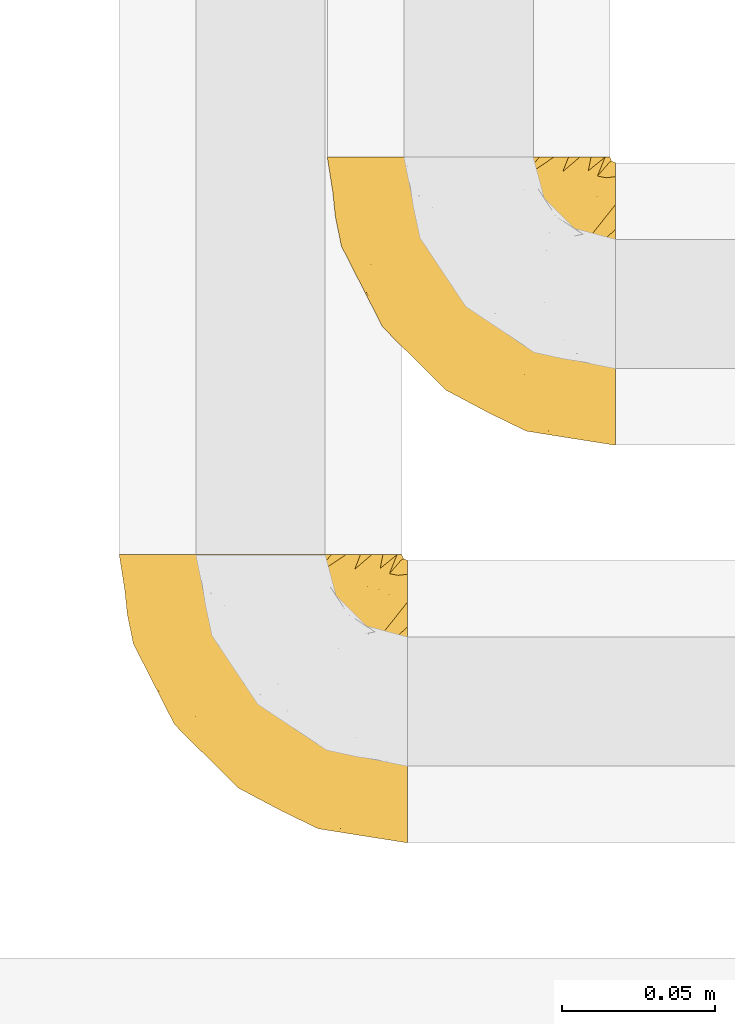
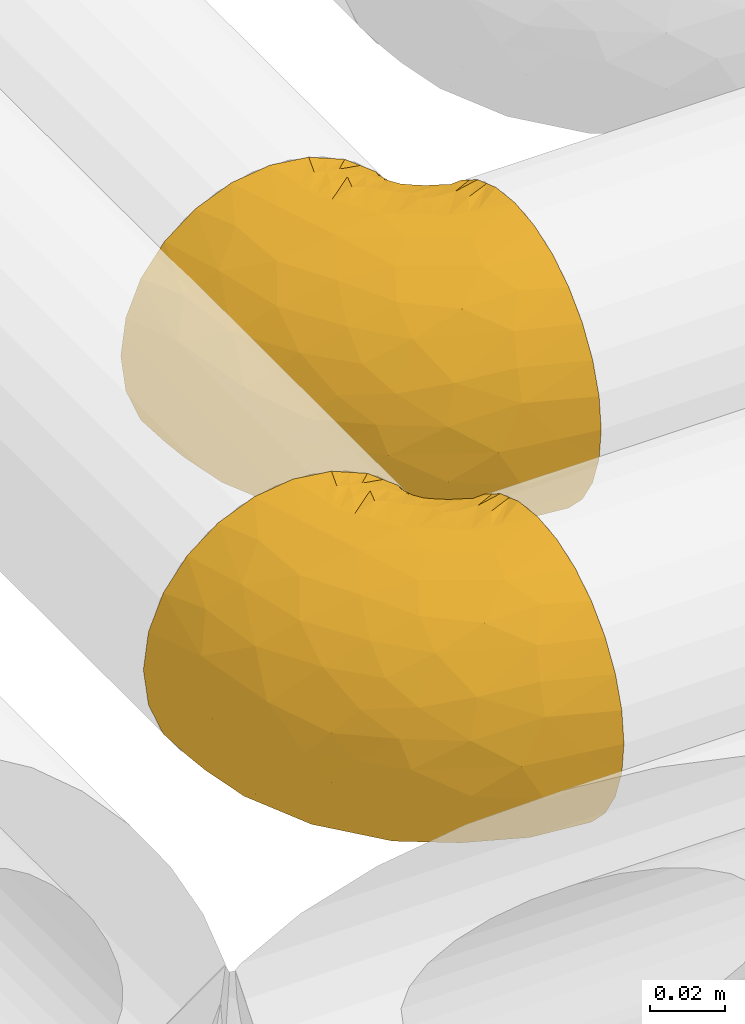
# One storey, part 259 of 827: 2 coverings.
"""IFC2X3 building model written with IfcOpenShell, lengths in millimetres."""

from ifc_helpers import new_model, entity, si_unit, converted_unit, derived_unit, direction, frame, origin, place, context, subcontext, project, spatial, faceted_brep, element, save


model = new_model("IFC2X3")

# Units and contexts
model_context = context("Model", 3, precision=0.01, world=origin(), true_north=direction((6.12303176911189e-17, 1.0)))
body_context = subcontext(model_context, "Body", "Model", "MODEL_VIEW")
ifc_project = project(units=[si_unit("LENGTHUNIT", "METRE", prefix="MILLI"), si_unit("AREAUNIT", "SQUARE_METRE"), si_unit("VOLUMEUNIT", "CUBIC_METRE"), converted_unit("PLANEANGLEUNIT", "DEGREE", entity("IfcRatioMeasure", 0.0174532925199433), si_unit("PLANEANGLEUNIT", "RADIAN"), dimensions=[0, 0, 0, 0, 0, 0, 0]), si_unit("MASSUNIT", "GRAM", prefix="KILO"), derived_unit("MASSDENSITYUNIT", [(si_unit("MASSUNIT", "GRAM", prefix="KILO"), 1), (si_unit("LENGTHUNIT", "METRE"), -3)]), derived_unit("MOMENTOFINERTIAUNIT", [(si_unit("LENGTHUNIT", "METRE"), 4)]), si_unit("TIMEUNIT", "SECOND"), si_unit("FREQUENCYUNIT", "HERTZ"), si_unit("THERMODYNAMICTEMPERATUREUNIT", "DEGREE_CELSIUS"), derived_unit("THERMALTRANSMITTANCEUNIT", [(si_unit("MASSUNIT", "GRAM", prefix="KILO"), 1), (si_unit("THERMODYNAMICTEMPERATUREUNIT", "KELVIN"), -1), (si_unit("TIMEUNIT", "SECOND"), -3)]), derived_unit("VOLUMETRICFLOWRATEUNIT", [(si_unit("LENGTHUNIT", "METRE"), 3), (si_unit("TIMEUNIT", "SECOND"), -1)]), derived_unit("MASSFLOWRATEUNIT", [(si_unit("MASSUNIT", "GRAM", prefix="KILO"), 1), (si_unit("TIMEUNIT", "SECOND"), -1)]), derived_unit("ROTATIONALFREQUENCYUNIT", [(si_unit("TIMEUNIT", "SECOND"), -1)]), si_unit("ELECTRICCURRENTUNIT", "AMPERE"), si_unit("ELECTRICVOLTAGEUNIT", "VOLT"), si_unit("POWERUNIT", "WATT"), si_unit("FORCEUNIT", "NEWTON", prefix="KILO"), si_unit("ILLUMINANCEUNIT", "LUX"), si_unit("LUMINOUSFLUXUNIT", "LUMEN"), si_unit("LUMINOUSINTENSITYUNIT", "CANDELA"), derived_unit("USERDEFINED", [(si_unit("MASSUNIT", "GRAM", prefix="KILO"), -1), (si_unit("LENGTHUNIT", "METRE"), -2), (si_unit("TIMEUNIT", "SECOND"), 3), (si_unit("LUMINOUSFLUXUNIT", "LUMEN"), 1)]), derived_unit("LINEARVELOCITYUNIT", [(si_unit("LENGTHUNIT", "METRE"), 1), (si_unit("TIMEUNIT", "SECOND"), -1)]), si_unit("PRESSUREUNIT", "PASCAL"), derived_unit("USERDEFINED", [(si_unit("LENGTHUNIT", "METRE"), -2), (si_unit("MASSUNIT", "GRAM", prefix="KILO"), 1), (si_unit("TIMEUNIT", "SECOND"), -2)]), derived_unit("LINEARFORCEUNIT", [(si_unit("MASSUNIT", "GRAM", prefix="KILO"), 1), (si_unit("LENGTHUNIT", "METRE"), 1), (si_unit("TIMEUNIT", "SECOND"), -2), (si_unit("LENGTHUNIT", "METRE"), -1)]), derived_unit("PLANARFORCEUNIT", [(si_unit("MASSUNIT", "GRAM", prefix="KILO"), 1), (si_unit("LENGTHUNIT", "METRE"), 1), (si_unit("TIMEUNIT", "SECOND"), -2), (si_unit("LENGTHUNIT", "METRE"), -2)])], contexts=[model_context])

# Site, building, storey
site_placement = place(None, origin())
site = spatial("IfcSite", under=ifc_project, at=site_placement, CompositionType="ELEMENT")
building_placement = place(site_placement, origin())
building = spatial("IfcBuilding", under=site, at=building_placement, CompositionType="ELEMENT")
storey_placement = place(building_placement, frame((0.0, 0.0, 28200.0)))
storey = spatial("IfcBuildingStorey", under=building, at=storey_placement, Name="08", CompositionType="ELEMENT", Elevation=28200.0)

# Coverings
covering_1_placement = place(storey_placement, frame((30677.28, 17203.41, 2952.2)))
element("IfcCovering", 1, at=covering_1_placement, inside=storey, Name=":ADSK_", ObjectType=":ADSK_", PredefinedType="INSULATION", context=body_context, shape_type="Brep", body=[
    faceted_brep([(95.8, 37.51, 92.84), (95.8, 27.74, 89.42), (95.8, 18.98, 83.91), (95.8, 11.67, 76.59), (95.8, 6.17, 67.83), (95.8, 2.75, 58.07), (95.8, 1.6, 47.8), (95.8, 2.75, 37.51), (95.8, 6.17, 27.74), (95.8, 11.68, 18.98), (95.8, 19.0, 11.67), (95.8, 27.76, 6.17), (95.8, 37.52, 2.75), (95.8, 47.8, 1.6), (95.8, 51.94, 2.06), (95.8, 55.01, 2.41), (95.8, 58.08, 2.75), (95.8, 62.96, 4.46), (95.8, 67.85, 6.17), (95.8, 72.23, 8.93), (95.8, 76.61, 11.68), (95.8, 80.26, 15.34), (95.8, 83.92, 19.0), (95.8, 89.42, 27.76), (95.8, 91.13, 32.64), (95.8, 92.84, 37.52), (95.8, 94.0, 47.8), (95.8, 92.84, 58.08), (95.8, 91.13, 62.96), (95.8, 89.42, 67.85), (95.8, 83.91, 76.61), (95.8, 80.25, 80.26), (95.8, 76.59, 83.92), (95.8, 72.21, 86.67), (95.8, 67.83, 89.42), (95.8, 62.95, 91.13), (95.8, 58.07, 92.84), (95.8, 55.0, 93.18), (95.8, 51.94, 93.53), (95.8, 47.8, 94.0), (94.0, 95.8, 47.8), (92.42, 95.8, 35.84), (87.81, 95.8, 24.7), (84.13, 95.8, 19.91), (80.46, 95.8, 15.13), (75.68, 95.8, 11.46), (70.9, 95.8, 7.78), (65.32, 95.8, 5.48), (59.75, 95.8, 3.17), (56.14, 95.8, 2.69), (54.06, 95.8, 2.42), (51.97, 95.8, 2.14), (47.8, 95.8, 1.6), (35.84, 95.8, 3.17), (24.7, 95.8, 7.78), (15.13, 95.8, 15.13), (7.78, 95.8, 24.7), (3.17, 95.8, 35.84), (1.6, 95.8, 47.8), (3.17, 95.8, 59.75), (7.78, 95.8, 70.9), (15.13, 95.8, 80.46), (24.7, 95.8, 87.81), (35.84, 95.8, 92.42), (47.8, 95.8, 94.0), (51.97, 95.8, 93.45), (56.14, 95.8, 92.9), (59.75, 95.8, 92.42), (65.32, 95.8, 90.11), (70.9, 95.8, 87.81), (75.68, 95.8, 84.13), (80.46, 95.8, 80.46), (84.13, 95.8, 75.68), (87.81, 95.8, 70.9), (92.42, 95.8, 59.75), (15.84, 60.58, 71.98), (6.99, 74.11, 63.6), (14.39, 51.59, 59.72), (6.21, 66.69, 47.8), (4.26, 76.19, 55.16), (3.39, 84.43, 47.8), (31.2, 31.2, 63.76), (26.47, 42.88, 72.22), (11.44, 79.41, 74.18), (47.66, 60.7, 92.52), (61.85, 61.85, 94.0), (59.25, 65.75, 94.0), (56.65, 69.64, 94.0), (54.05, 73.53, 94.0), (51.45, 77.43, 94.0), (19.8, 74.59, 82.14), (26.22, 54.72, 80.34), (31.58, 64.18, 87.52), (38.36, 37.94, 79.59), (51.54, 25.89, 78.25), (51.6, 34.73, 85.01), (55.97, 42.89, 90.25), (62.88, 49.83, 93.2), (41.35, 48.58, 87.23), (82.24, 22.41, 85.55), (40.88, 78.69, 93.0), (29.0, 81.64, 89.31), (74.06, 6.22, 61.31), (54.53, 12.11, 56.86), (57.98, 14.81, 68.34), (43.81, 21.61, 65.71), (38.22, 22.41, 56.99), (38.33, 30.12, 72.15), (74.76, 10.01, 70.34), (76.85, 15.36, 78.36), (84.43, 3.39, 47.8), (40.43, 19.59, 47.8), (30.01, 30.01, 47.8), (78.67, 41.19, 93.06), (92.06, 48.54, 94.0), (88.32, 49.28, 94.0), (85.6, 49.82, 94.0), (82.88, 50.37, 94.0), (80.15, 50.91, 94.0), (77.43, 51.45, 94.0), (76.36, 31.61, 89.88), (50.91, 80.15, 94.0), (50.37, 82.88, 94.0), (49.82, 85.6, 94.0), (49.28, 88.32, 94.0), (48.91, 90.19, 94.0), (48.54, 92.06, 94.0), (66.69, 6.21, 47.8), (73.53, 54.05, 94.0), (69.64, 56.65, 94.0), (65.75, 59.25, 94.0), (66.13, 24.66, 83.7), (19.59, 40.43, 47.8), (24.64, 35.17, 55.9), (53.56, 12.9, 47.8), (12.9, 53.56, 47.8), (82.81, 85.34, 81.75), (81.22, 78.44, 86.43), (86.57, 84.37, 79.8), (92.75, 89.05, 69.84), (89.68, 82.76, 79.5), (72.26, 86.31, 88.08), (64.73, 83.73, 91.6), (62.45, 77.31, 92.93), (60.63, 87.78, 92.43), (56.91, 87.91, 93.24), (58.14, 81.29, 93.36), (93.7, 93.97, 57.25), (83.4, 70.76, 89.41), (75.54, 63.67, 92.89), (79.46, 62.62, 92.66), (82.28, 90.64, 79.58), (76.25, 84.08, 86.51), (90.18, 77.45, 83.91), (84.69, 76.28, 86.29), (65.12, 88.72, 90.94), (71.71, 71.28, 91.94), (75.21, 68.09, 91.98), (78.6, 91.07, 82.79), (87.27, 57.47, 93.16), (87.92, 70.34, 88.76), (86.94, 91.35, 73.94), (86.1, 62.99, 91.89), (94.52, 94.52, 47.8), (66.23, 76.47, 92.22), (91.08, 69.96, 88.56), (71.77, 89.86, 87.72), (76.21, 78.94, 88.33), (68.59, 73.51, 92.18), (89.94, 89.62, 71.78), (76.22, 78.96, 7.27), (81.22, 78.46, 9.17), (71.7, 71.31, 3.66), (48.54, 92.06, 1.6), (50.37, 82.88, 1.6), (49.82, 85.6, 1.6), (49.28, 88.32, 1.6), (93.7, 93.97, 38.35), (89.95, 89.63, 23.84), (82.88, 50.37, 1.6), (85.6, 49.82, 1.6), (92.06, 48.54, 1.6), (88.32, 49.28, 1.6), (89.68, 82.77, 16.1), (87.92, 70.36, 6.84), (62.45, 77.31, 2.66), (66.24, 76.47, 3.37), (56.65, 69.64, 1.6), (59.25, 65.75, 1.6), (78.6, 91.06, 12.8), (60.63, 87.78, 3.16), (56.91, 87.91, 2.35), (92.76, 89.06, 25.77), (76.25, 84.09, 9.09), (82.28, 90.65, 16.02), (82.81, 85.35, 13.85), (54.05, 73.53, 1.6), (51.45, 77.43, 1.6), (58.14, 81.29, 2.23), (90.18, 77.46, 11.69), (84.7, 76.29, 9.31), (87.25, 57.47, 2.43), (75.58, 63.71, 2.71), (75.2, 68.11, 3.61), (83.39, 70.77, 6.18), (90.73, 69.52, 6.77), (79.47, 62.64, 2.93), (86.94, 91.35, 21.66), (65.75, 59.25, 1.6), (86.75, 84.6, 16.09), (86.08, 62.98, 3.7), (77.43, 51.45, 1.6), (73.53, 54.05, 1.6), (69.64, 56.65, 1.6), (64.73, 83.73, 3.99), (50.91, 80.15, 1.6), (65.12, 88.72, 4.65), (72.26, 86.3, 7.51), (61.85, 61.85, 1.6), (68.62, 73.56, 3.43), (74.03, 91.36, 9.46), (80.15, 50.91, 1.6), (49.81, 62.87, 2.4), (4.26, 76.19, 40.43), (19.95, 73.57, 13.57), (30.61, 56.07, 11.3), (25.71, 49.77, 18.65), (22.43, 44.73, 27.26), (15.85, 60.58, 23.61), (60.69, 47.64, 3.07), (40.49, 78.32, 2.69), (14.39, 51.59, 35.87), (6.99, 74.11, 31.99), (29.56, 76.04, 6.71), (11.45, 79.41, 21.41), (57.98, 14.82, 27.24), (74.06, 6.22, 34.26), (54.52, 12.12, 38.73), (43.47, 23.51, 26.97), (31.2, 31.2, 31.83), (33.27, 34.96, 23.4), (64.26, 33.86, 6.91), (74.29, 38.94, 3.4), (80.41, 30.23, 5.84), (24.64, 35.17, 39.69), (73.62, 15.85, 17.6), (78.98, 22.59, 10.38), (53.69, 21.56, 20.6), (42.86, 55.94, 5.36), (41.67, 20.67, 35.73), (79.66, 9.19, 24.84), (58.41, 25.79, 13.87), (47.11, 41.16, 9.06), (38.37, 37.95, 15.99)], [[[0, 1, 2, 3, 4, 5, 6, 7, 8, 9, 10, 11, 12, 13, 14, 15, 16, 17, 18, 19, 20, 21, 22, 23, 24, 25, 26, 27, 28, 29, 30, 31, 32, 33, 34, 35, 36, 37, 38, 39]], [[40, 41, 42, 43, 44, 45, 46, 47, 48, 49, 50, 51, 52, 53, 54, 55, 56, 57, 58, 59, 60, 61, 62, 63, 64, 65, 66, 67, 68, 69, 70, 71, 72, 73, 74]], [[75, 76, 77]], [[78, 79, 80]], [[77, 81, 82]], [[76, 75, 83]], [[84, 85, 86, 87, 88, 89]], [[90, 91, 92]], [[76, 60, 59]], [[93, 94, 95]], [[90, 62, 61]], [[83, 61, 60]], [[96, 97, 84]], [[98, 93, 95]], [[2, 1, 99]], [[100, 84, 89]], [[62, 101, 63]], [[4, 102, 5]], [[92, 84, 100]], [[103, 102, 104]], [[103, 105, 106]], [[93, 107, 94]], [[3, 108, 4]], [[92, 101, 90]], [[108, 3, 109]], [[102, 110, 5]], [[93, 82, 107]], [[102, 108, 104]], [[111, 106, 112]], [[109, 2, 99]], [[113, 39, 114, 115, 116, 117, 118, 119]], [[120, 0, 113]], [[100, 89, 121, 122, 123, 124, 125, 126, 64]], [[127, 102, 103]], [[97, 119, 128, 129, 130, 85]], [[99, 120, 131]], [[132, 133, 77]], [[59, 80, 79]], [[3, 2, 109]], [[98, 84, 92]], [[94, 109, 131]], [[120, 1, 0]], [[93, 91, 82]], [[104, 94, 105]], [[97, 113, 119]], [[95, 120, 96]], [[83, 90, 61]], [[91, 93, 98]], [[64, 63, 100]], [[100, 63, 101]], [[77, 76, 79]], [[133, 106, 81]], [[84, 97, 85]], [[113, 96, 120]], [[113, 97, 96]], [[39, 113, 0]], [[110, 102, 127]], [[110, 6, 5]], [[103, 111, 134, 127]], [[90, 75, 91]], [[82, 81, 107]], [[91, 75, 82]], [[77, 82, 75]], [[76, 83, 60]], [[90, 83, 75]], [[105, 107, 81]], [[94, 131, 95]], [[105, 94, 107]], [[109, 94, 104]], [[120, 95, 131]], [[98, 95, 96]], [[84, 98, 96]], [[98, 92, 91]], [[106, 105, 81]], [[103, 104, 105]], [[133, 132, 112]], [[103, 106, 111]], [[77, 78, 135, 132]], [[106, 133, 112]], [[77, 133, 81]], [[120, 99, 1]], [[109, 99, 131]], [[59, 58, 80]], [[59, 79, 76]], [[90, 101, 62]], [[100, 101, 92]], [[4, 108, 102]], [[109, 104, 108]], [[78, 77, 79]], [[136, 137, 138]], [[29, 139, 140]], [[141, 142, 143]], [[144, 145, 121]], [[146, 89, 88]], [[147, 139, 27]], [[148, 149, 150]], [[136, 151, 152]], [[147, 40, 74]], [[26, 147, 27]], [[153, 140, 154]], [[35, 116, 36]], [[73, 72, 151]], [[114, 39, 38, 37, 36, 116, 115]], [[146, 155, 144]], [[156, 85, 130]], [[157, 149, 148]], [[151, 158, 152]], [[117, 35, 159]], [[31, 153, 160]], [[161, 74, 73]], [[162, 128, 119]], [[65, 64, 126, 125, 124, 123, 122, 67, 66]], [[163, 147, 26]], [[29, 140, 30]], [[149, 129, 150]], [[139, 29, 28, 27]], [[68, 144, 69]], [[129, 128, 150]], [[164, 87, 86]], [[130, 129, 149]], [[122, 145, 67]], [[153, 154, 148]], [[162, 119, 159]], [[165, 32, 160]], [[150, 160, 148]], [[128, 162, 150]], [[32, 165, 33]], [[145, 144, 68]], [[89, 146, 144]], [[87, 164, 143]], [[166, 155, 142]], [[88, 87, 143]], [[162, 160, 150]], [[160, 32, 31]], [[160, 153, 148]], [[30, 140, 153]], [[31, 30, 153]], [[140, 137, 154]], [[157, 148, 154]], [[156, 130, 157]], [[154, 137, 157]], [[157, 137, 156]], [[167, 137, 136]], [[168, 85, 156]], [[152, 168, 167]], [[167, 168, 156]], [[164, 152, 141]], [[71, 158, 72]], [[152, 167, 136]], [[88, 142, 146]], [[144, 155, 69]], [[146, 142, 155]], [[70, 166, 71]], [[142, 141, 166]], [[70, 69, 155]], [[141, 158, 71]], [[161, 73, 151]], [[138, 137, 140]], [[161, 136, 169]], [[136, 161, 151]], [[74, 161, 169]], [[152, 158, 141]], [[151, 72, 158]], [[168, 152, 164]], [[137, 167, 156]], [[164, 86, 168]], [[85, 168, 86]], [[116, 35, 117]], [[130, 149, 157]], [[67, 145, 68]], [[121, 89, 144]], [[145, 122, 121]], [[40, 147, 163]], [[169, 147, 74]], [[159, 35, 34]], [[162, 159, 34]], [[159, 119, 118, 117]], [[139, 147, 169]], [[139, 169, 138]], [[162, 34, 33]], [[141, 143, 164]], [[88, 143, 142]], [[71, 166, 141]], [[155, 166, 70]], [[139, 138, 140]], [[169, 136, 138]], [[160, 162, 165]], [[162, 33, 165]], [[170, 171, 172]], [[173, 52, 51, 50, 49, 48, 174, 175, 176]], [[177, 178, 41]], [[179, 17, 180]], [[14, 13, 181, 182, 180, 16, 15]], [[183, 23, 22]], [[21, 20, 184]], [[185, 186, 187]], [[186, 188, 187]], [[43, 189, 44]], [[190, 191, 47]], [[25, 24, 23, 192]], [[193, 194, 195]], [[40, 163, 177]], [[196, 197, 198]], [[26, 25, 177]], [[199, 200, 183]], [[201, 17, 179]], [[47, 46, 190]], [[202, 203, 204]], [[203, 172, 171]], [[205, 206, 184]], [[207, 41, 178]], [[18, 17, 201]], [[16, 180, 17]], [[204, 203, 200]], [[208, 203, 202]], [[163, 26, 177]], [[48, 47, 191]], [[198, 197, 190]], [[199, 184, 204]], [[171, 195, 209]], [[210, 211, 212]], [[206, 212, 213]], [[205, 19, 210]], [[184, 206, 204]], [[210, 212, 206]], [[185, 196, 214]], [[190, 215, 191]], [[216, 45, 214]], [[186, 217, 193]], [[190, 216, 198]], [[21, 184, 199]], [[196, 185, 187]], [[21, 199, 22]], [[200, 199, 204]], [[183, 22, 199]], [[206, 202, 204]], [[171, 183, 200]], [[203, 208, 172]], [[172, 208, 218]], [[171, 200, 203]], [[218, 188, 219]], [[195, 170, 193]], [[217, 186, 185]], [[193, 219, 186]], [[193, 170, 219]], [[207, 194, 42]], [[217, 220, 189]], [[216, 190, 46]], [[214, 196, 198]], [[44, 220, 45]], [[214, 198, 216]], [[216, 46, 45]], [[214, 45, 220]], [[42, 194, 43]], [[189, 193, 217]], [[207, 195, 194]], [[209, 195, 178]], [[41, 207, 42]], [[195, 207, 178]], [[43, 194, 189]], [[193, 189, 194]], [[171, 170, 195]], [[170, 172, 219]], [[218, 219, 172]], [[188, 186, 219]], [[206, 213, 202]], [[208, 202, 213]], [[201, 210, 18]], [[215, 190, 197]], [[215, 174, 191]], [[174, 48, 191]], [[201, 179, 221, 211]], [[210, 201, 211]], [[25, 192, 177]], [[40, 177, 41]], [[183, 209, 192]], [[183, 192, 23]], [[192, 178, 177]], [[205, 20, 19]], [[19, 18, 210]], [[217, 185, 214]], [[189, 220, 44]], [[214, 220, 217]], [[192, 209, 178]], [[171, 209, 183]], [[206, 205, 210]], [[20, 205, 184]], [[222, 197, 196, 187, 188, 218]], [[57, 223, 80]], [[224, 225, 226]], [[226, 227, 228]], [[229, 218, 208, 213, 212, 211]], [[230, 52, 173, 176, 175, 174, 215, 197]], [[231, 232, 228]], [[231, 78, 223]], [[223, 57, 232]], [[224, 233, 225]], [[233, 54, 53]], [[234, 232, 56]], [[56, 55, 234]], [[234, 224, 228]], [[235, 236, 237]], [[224, 55, 54]], [[238, 239, 240]], [[52, 230, 53]], [[241, 242, 243]], [[227, 244, 231]], [[13, 12, 242]], [[236, 8, 7]], [[9, 245, 10]], [[10, 246, 11]], [[238, 247, 235]], [[222, 229, 248]], [[242, 211, 221, 179, 180, 182, 181, 13]], [[233, 53, 230]], [[111, 112, 249]], [[250, 8, 236]], [[246, 251, 241]], [[8, 250, 9]], [[127, 236, 110]], [[248, 229, 252]], [[246, 10, 245]], [[235, 245, 250]], [[236, 7, 110]], [[235, 249, 238]], [[237, 236, 127]], [[243, 11, 246]], [[252, 229, 241]], [[56, 232, 57]], [[222, 230, 197]], [[225, 248, 252]], [[248, 233, 230]], [[54, 233, 224]], [[231, 228, 227]], [[244, 132, 231]], [[248, 225, 233]], [[226, 225, 253]], [[235, 250, 236]], [[245, 9, 250]], [[251, 246, 245]], [[243, 246, 241]], [[247, 245, 235]], [[252, 251, 253]], [[229, 222, 218]], [[230, 222, 248]], [[7, 6, 110]], [[237, 127, 134, 111]], [[238, 249, 239]], [[224, 234, 55]], [[232, 234, 228]], [[242, 241, 229]], [[12, 11, 243]], [[211, 242, 229]], [[12, 243, 242]], [[80, 223, 78]], [[80, 58, 57]], [[231, 223, 232]], [[227, 240, 239]], [[224, 226, 228]], [[240, 226, 253]], [[227, 239, 244]], [[226, 240, 227]], [[251, 247, 253]], [[240, 253, 247]], [[249, 235, 237]], [[237, 111, 249]], [[112, 132, 244]], [[112, 244, 249]], [[78, 231, 132, 135]], [[249, 244, 239]], [[247, 238, 240]], [[245, 247, 251]], [[251, 252, 241]], [[225, 252, 253]]]),
])
covering_2_placement = place(storey_placement, frame((30609.25, 17073.41, 2952.2)))
element("IfcCovering", 2, at=covering_2_placement, inside=storey, Name=":ADSK_", ObjectType=":ADSK_", PredefinedType="INSULATION", context=body_context, shape_type="Brep", body=[
    faceted_brep([(95.8, 37.51, 92.84), (95.8, 27.74, 89.42), (95.8, 18.98, 83.91), (95.8, 11.67, 76.59), (95.8, 6.17, 67.83), (95.8, 2.75, 58.07), (95.8, 1.6, 47.8), (95.8, 2.75, 37.51), (95.8, 6.17, 27.74), (95.8, 11.68, 18.98), (95.8, 19.0, 11.67), (95.8, 27.76, 6.17), (95.8, 37.52, 2.75), (95.8, 47.8, 1.6), (95.8, 51.94, 2.06), (95.8, 55.01, 2.41), (95.8, 58.08, 2.75), (95.8, 62.96, 4.46), (95.8, 67.85, 6.17), (95.8, 72.23, 8.93), (95.8, 76.61, 11.68), (95.8, 80.26, 15.34), (95.8, 83.92, 19.0), (95.8, 89.42, 27.76), (95.8, 91.13, 32.64), (95.8, 92.84, 37.52), (95.8, 94.0, 47.8), (95.8, 92.84, 58.08), (95.8, 91.13, 62.96), (95.8, 89.42, 67.85), (95.8, 83.91, 76.61), (95.8, 80.25, 80.26), (95.8, 76.59, 83.92), (95.8, 72.21, 86.67), (95.8, 67.83, 89.42), (95.8, 62.95, 91.13), (95.8, 58.07, 92.84), (95.8, 55.0, 93.18), (95.8, 51.94, 93.53), (95.8, 47.8, 94.0), (94.0, 95.8, 47.8), (92.42, 95.8, 35.84), (87.81, 95.8, 24.7), (84.13, 95.8, 19.91), (80.46, 95.8, 15.13), (75.68, 95.8, 11.46), (70.9, 95.8, 7.78), (65.32, 95.8, 5.48), (59.75, 95.8, 3.17), (56.14, 95.8, 2.69), (54.06, 95.8, 2.42), (51.97, 95.8, 2.14), (47.8, 95.8, 1.6), (35.84, 95.8, 3.17), (24.7, 95.8, 7.78), (15.13, 95.8, 15.13), (7.78, 95.8, 24.7), (3.17, 95.8, 35.84), (1.6, 95.8, 47.8), (3.17, 95.8, 59.75), (7.78, 95.8, 70.9), (15.13, 95.8, 80.46), (24.7, 95.8, 87.81), (35.84, 95.8, 92.42), (47.8, 95.8, 94.0), (51.97, 95.8, 93.45), (56.14, 95.8, 92.9), (59.75, 95.8, 92.42), (65.32, 95.8, 90.11), (70.9, 95.8, 87.81), (75.68, 95.8, 84.13), (80.46, 95.8, 80.46), (84.13, 95.8, 75.68), (87.81, 95.8, 70.9), (92.42, 95.8, 59.75), (15.84, 60.58, 71.98), (6.99, 74.11, 63.6), (14.39, 51.59, 59.72), (6.21, 66.69, 47.8), (4.26, 76.19, 55.16), (3.39, 84.43, 47.8), (31.2, 31.2, 63.76), (26.47, 42.88, 72.22), (11.44, 79.41, 74.18), (47.66, 60.7, 92.52), (61.85, 61.85, 94.0), (59.25, 65.75, 94.0), (56.65, 69.64, 94.0), (54.05, 73.53, 94.0), (51.45, 77.43, 94.0), (19.8, 74.59, 82.14), (26.22, 54.72, 80.34), (31.58, 64.18, 87.52), (38.36, 37.94, 79.59), (51.54, 25.89, 78.25), (51.6, 34.73, 85.01), (55.97, 42.89, 90.25), (62.88, 49.83, 93.2), (41.35, 48.58, 87.23), (82.24, 22.41, 85.55), (40.88, 78.69, 93.0), (29.0, 81.64, 89.31), (74.06, 6.22, 61.31), (54.53, 12.11, 56.86), (57.98, 14.81, 68.34), (43.81, 21.61, 65.71), (38.22, 22.41, 56.99), (38.33, 30.12, 72.15), (74.76, 10.01, 70.34), (76.85, 15.36, 78.36), (84.43, 3.39, 47.8), (40.43, 19.59, 47.8), (30.01, 30.01, 47.8), (78.67, 41.19, 93.06), (92.06, 48.54, 94.0), (88.32, 49.28, 94.0), (85.6, 49.82, 94.0), (82.88, 50.37, 94.0), (80.15, 50.91, 94.0), (77.43, 51.45, 94.0), (76.36, 31.61, 89.88), (50.91, 80.15, 94.0), (50.37, 82.88, 94.0), (49.82, 85.6, 94.0), (49.28, 88.32, 94.0), (48.91, 90.19, 94.0), (48.54, 92.06, 94.0), (66.69, 6.21, 47.8), (73.53, 54.05, 94.0), (69.64, 56.65, 94.0), (65.75, 59.25, 94.0), (66.13, 24.66, 83.7), (19.59, 40.43, 47.8), (24.64, 35.17, 55.9), (53.56, 12.9, 47.8), (12.9, 53.56, 47.8), (82.81, 85.34, 81.75), (81.22, 78.44, 86.43), (86.57, 84.37, 79.8), (92.75, 89.05, 69.84), (89.68, 82.76, 79.5), (72.26, 86.31, 88.08), (64.73, 83.73, 91.6), (62.45, 77.31, 92.93), (60.63, 87.78, 92.43), (56.91, 87.91, 93.24), (58.14, 81.29, 93.36), (93.7, 93.97, 57.25), (83.4, 70.76, 89.41), (75.54, 63.67, 92.89), (79.46, 62.62, 92.66), (82.28, 90.64, 79.58), (76.25, 84.08, 86.51), (84.69, 76.28, 86.29), (90.18, 77.45, 83.91), (86.94, 91.35, 73.94), (65.12, 88.72, 90.94), (71.71, 71.28, 91.94), (75.21, 68.09, 91.98), (78.6, 91.07, 82.79), (87.27, 57.47, 93.16), (87.92, 70.34, 88.76), (86.1, 62.99, 91.89), (94.52, 94.52, 47.8), (66.23, 76.47, 92.22), (91.08, 69.96, 88.56), (71.77, 89.86, 87.72), (76.21, 78.94, 88.33), (68.59, 73.51, 92.18), (89.94, 89.62, 71.78), (76.25, 84.09, 9.09), (72.26, 86.3, 7.51), (78.6, 91.06, 12.8), (49.28, 88.32, 1.6), (48.54, 92.06, 1.6), (50.37, 82.88, 1.6), (49.82, 85.6, 1.6), (93.7, 93.97, 38.35), (89.95, 89.63, 23.84), (82.88, 50.37, 1.6), (85.6, 49.82, 1.6), (92.06, 48.54, 1.6), (88.32, 49.28, 1.6), (89.68, 82.77, 16.1), (87.92, 70.36, 6.84), (62.45, 77.31, 2.66), (66.24, 76.47, 3.37), (56.65, 69.64, 1.6), (59.25, 65.75, 1.6), (60.63, 87.78, 3.16), (56.91, 87.91, 2.35), (92.76, 89.06, 25.77), (82.28, 90.65, 16.02), (82.81, 85.35, 13.85), (54.05, 73.53, 1.6), (51.45, 77.43, 1.6), (58.14, 81.29, 2.23), (90.18, 77.46, 11.69), (84.7, 76.29, 9.31), (87.25, 57.47, 2.43), (75.58, 63.71, 2.71), (75.2, 68.11, 3.61), (83.39, 70.77, 6.18), (71.7, 71.31, 3.66), (81.22, 78.46, 9.17), (90.73, 69.52, 6.77), (79.47, 62.64, 2.93), (86.94, 91.35, 21.66), (65.75, 59.25, 1.6), (86.75, 84.6, 16.09), (86.08, 62.98, 3.7), (77.43, 51.45, 1.6), (73.53, 54.05, 1.6), (69.64, 56.65, 1.6), (64.73, 83.73, 3.99), (50.91, 80.15, 1.6), (65.12, 88.72, 4.65), (61.85, 61.85, 1.6), (68.62, 73.56, 3.43), (76.22, 78.96, 7.27), (74.03, 91.36, 9.46), (80.15, 50.91, 1.6), (49.81, 62.87, 2.4), (4.26, 76.19, 40.43), (19.95, 73.57, 13.57), (30.61, 56.07, 11.3), (25.71, 49.77, 18.65), (22.43, 44.73, 27.26), (15.85, 60.58, 23.61), (60.69, 47.64, 3.07), (40.49, 78.32, 2.69), (14.39, 51.59, 35.87), (6.99, 74.11, 31.99), (29.56, 76.04, 6.71), (11.45, 79.41, 21.41), (57.98, 14.82, 27.24), (74.06, 6.22, 34.26), (54.52, 12.12, 38.73), (43.47, 23.51, 26.97), (31.2, 31.2, 31.83), (33.27, 34.96, 23.4), (64.26, 33.86, 6.91), (74.29, 38.94, 3.4), (80.41, 30.23, 5.84), (41.67, 20.67, 35.73), (24.64, 35.17, 39.69), (73.62, 15.85, 17.6), (78.98, 22.59, 10.38), (53.69, 21.56, 20.6), (42.86, 55.94, 5.36), (79.66, 9.19, 24.84), (58.41, 25.79, 13.87), (47.11, 41.16, 9.06), (38.37, 37.95, 15.99)], [[[0, 1, 2, 3, 4, 5, 6, 7, 8, 9, 10, 11, 12, 13, 14, 15, 16, 17, 18, 19, 20, 21, 22, 23, 24, 25, 26, 27, 28, 29, 30, 31, 32, 33, 34, 35, 36, 37, 38, 39]], [[40, 41, 42, 43, 44, 45, 46, 47, 48, 49, 50, 51, 52, 53, 54, 55, 56, 57, 58, 59, 60, 61, 62, 63, 64, 65, 66, 67, 68, 69, 70, 71, 72, 73, 74]], [[75, 76, 77]], [[78, 79, 80]], [[77, 81, 82]], [[76, 75, 83]], [[84, 85, 86, 87, 88, 89]], [[90, 91, 92]], [[76, 60, 59]], [[93, 94, 95]], [[90, 62, 61]], [[83, 61, 60]], [[96, 97, 84]], [[98, 93, 95]], [[2, 1, 99]], [[100, 84, 89]], [[62, 101, 63]], [[4, 102, 5]], [[92, 84, 100]], [[103, 102, 104]], [[103, 105, 106]], [[93, 107, 94]], [[3, 108, 4]], [[92, 101, 90]], [[108, 3, 109]], [[102, 110, 5]], [[93, 82, 107]], [[102, 108, 104]], [[111, 106, 112]], [[109, 2, 99]], [[113, 39, 114, 115, 116, 117, 118, 119]], [[120, 0, 113]], [[100, 89, 121, 122, 123, 124, 125, 126, 64]], [[127, 102, 103]], [[97, 119, 128, 129, 130, 85]], [[99, 120, 131]], [[132, 133, 77]], [[59, 80, 79]], [[3, 2, 109]], [[98, 84, 92]], [[94, 109, 131]], [[120, 1, 0]], [[93, 91, 82]], [[104, 94, 105]], [[97, 113, 119]], [[95, 120, 96]], [[83, 90, 61]], [[91, 93, 98]], [[64, 63, 100]], [[100, 63, 101]], [[77, 76, 79]], [[133, 106, 81]], [[84, 97, 85]], [[113, 96, 120]], [[113, 97, 96]], [[39, 113, 0]], [[110, 102, 127]], [[110, 6, 5]], [[103, 111, 134, 127]], [[90, 75, 91]], [[82, 81, 107]], [[91, 75, 82]], [[77, 82, 75]], [[76, 83, 60]], [[90, 83, 75]], [[105, 107, 81]], [[94, 131, 95]], [[105, 94, 107]], [[109, 94, 104]], [[120, 95, 131]], [[98, 95, 96]], [[84, 98, 96]], [[98, 92, 91]], [[106, 105, 81]], [[103, 104, 105]], [[133, 132, 112]], [[103, 106, 111]], [[77, 78, 135, 132]], [[81, 77, 133]], [[106, 133, 112]], [[120, 99, 1]], [[109, 99, 131]], [[59, 58, 80]], [[59, 79, 76]], [[90, 101, 62]], [[100, 101, 92]], [[4, 108, 102]], [[109, 104, 108]], [[78, 77, 79]], [[136, 137, 138]], [[29, 139, 140]], [[141, 142, 143]], [[144, 145, 121]], [[146, 89, 88]], [[147, 139, 27]], [[148, 149, 150]], [[136, 151, 152]], [[147, 40, 74]], [[26, 147, 27]], [[140, 153, 154]], [[35, 116, 36]], [[73, 151, 155]], [[114, 39, 38, 37, 36, 116, 115]], [[146, 156, 144]], [[157, 85, 130]], [[158, 149, 148]], [[151, 159, 152]], [[117, 35, 160]], [[31, 154, 161]], [[155, 74, 73]], [[162, 128, 119]], [[66, 65, 64, 126, 125, 124, 123, 122, 67]], [[163, 147, 26]], [[29, 140, 30]], [[149, 129, 150]], [[139, 29, 28, 27]], [[68, 144, 69]], [[129, 128, 150]], [[164, 87, 86]], [[130, 129, 149]], [[122, 145, 67]], [[154, 153, 148]], [[162, 119, 160]], [[165, 32, 161]], [[150, 161, 148]], [[128, 162, 150]], [[32, 165, 33]], [[145, 144, 68]], [[89, 146, 144]], [[87, 164, 143]], [[166, 156, 142]], [[88, 87, 143]], [[162, 161, 150]], [[161, 32, 31]], [[154, 31, 30]], [[140, 154, 30]], [[161, 154, 148]], [[140, 137, 153]], [[158, 148, 153]], [[157, 130, 158]], [[153, 137, 158]], [[158, 137, 157]], [[167, 137, 136]], [[168, 85, 157]], [[152, 168, 167]], [[167, 168, 157]], [[164, 152, 141]], [[151, 73, 72]], [[159, 72, 71]], [[88, 142, 146]], [[144, 156, 69]], [[146, 142, 156]], [[70, 166, 71]], [[142, 141, 166]], [[70, 69, 156]], [[141, 159, 71]], [[167, 136, 152]], [[138, 137, 140]], [[155, 136, 169]], [[136, 155, 151]], [[74, 155, 169]], [[152, 159, 141]], [[151, 72, 159]], [[168, 152, 164]], [[137, 167, 157]], [[164, 86, 168]], [[85, 168, 86]], [[116, 35, 117]], [[130, 149, 158]], [[67, 145, 68]], [[121, 89, 144]], [[145, 122, 121]], [[40, 147, 163]], [[169, 147, 74]], [[160, 35, 34]], [[162, 160, 34]], [[160, 119, 118, 117]], [[139, 147, 169]], [[139, 169, 138]], [[162, 34, 33]], [[141, 143, 164]], [[88, 143, 142]], [[71, 166, 141]], [[156, 166, 70]], [[139, 138, 140]], [[169, 136, 138]], [[161, 162, 165]], [[162, 33, 165]], [[170, 171, 172]], [[173, 174, 52, 51, 50, 49, 48, 175, 176]], [[177, 178, 41]], [[179, 17, 180]], [[14, 13, 181, 182, 180, 16, 15]], [[183, 23, 22]], [[21, 20, 184]], [[185, 186, 187]], [[186, 188, 187]], [[43, 172, 44]], [[189, 190, 47]], [[25, 24, 23, 191]], [[170, 192, 193]], [[40, 163, 177]], [[194, 195, 196]], [[26, 25, 177]], [[197, 198, 183]], [[199, 17, 179]], [[47, 46, 189]], [[200, 201, 202]], [[201, 203, 204]], [[205, 206, 184]], [[207, 41, 178]], [[18, 17, 199]], [[16, 180, 17]], [[202, 201, 198]], [[208, 201, 200]], [[163, 26, 177]], [[48, 47, 190]], [[196, 195, 189]], [[197, 184, 202]], [[204, 193, 209]], [[210, 211, 212]], [[206, 212, 213]], [[205, 19, 210]], [[184, 206, 202]], [[210, 212, 206]], [[185, 194, 214]], [[189, 215, 190]], [[216, 45, 214]], [[186, 171, 170]], [[189, 216, 196]], [[197, 22, 21]], [[194, 185, 187]], [[197, 183, 22]], [[184, 197, 21]], [[197, 202, 198]], [[206, 200, 202]], [[204, 183, 198]], [[201, 208, 203]], [[203, 208, 217]], [[204, 198, 201]], [[217, 188, 218]], [[193, 219, 170]], [[171, 186, 185]], [[170, 218, 186]], [[170, 219, 218]], [[42, 207, 192]], [[171, 220, 172]], [[216, 189, 46]], [[214, 194, 196]], [[44, 220, 45]], [[214, 196, 216]], [[216, 46, 45]], [[214, 45, 220]], [[192, 43, 42]], [[204, 203, 219]], [[207, 193, 192]], [[209, 193, 178]], [[41, 207, 42]], [[193, 207, 178]], [[43, 192, 172]], [[170, 172, 192]], [[204, 219, 193]], [[219, 203, 218]], [[217, 218, 203]], [[188, 186, 218]], [[206, 213, 200]], [[208, 200, 213]], [[199, 210, 18]], [[215, 189, 195]], [[215, 175, 190]], [[175, 48, 190]], [[199, 179, 221, 211]], [[210, 199, 211]], [[25, 191, 177]], [[40, 177, 41]], [[183, 209, 191]], [[183, 191, 23]], [[191, 178, 177]], [[205, 20, 19]], [[19, 18, 210]], [[171, 185, 214]], [[172, 220, 44]], [[214, 220, 171]], [[191, 209, 178]], [[204, 209, 183]], [[206, 205, 210]], [[20, 205, 184]], [[222, 195, 194, 187, 188, 217]], [[57, 223, 80]], [[224, 225, 226]], [[226, 227, 228]], [[229, 217, 208, 213, 212, 211]], [[230, 52, 174, 173, 176, 175, 215, 195]], [[231, 232, 228]], [[231, 78, 223]], [[223, 57, 232]], [[224, 233, 225]], [[233, 54, 53]], [[234, 232, 56]], [[56, 55, 234]], [[234, 224, 228]], [[235, 236, 237]], [[224, 55, 54]], [[238, 239, 240]], [[52, 230, 53]], [[241, 242, 243]], [[239, 244, 245]], [[13, 12, 242]], [[236, 8, 7]], [[9, 246, 10]], [[10, 247, 11]], [[238, 248, 235]], [[222, 229, 249]], [[242, 211, 221, 179, 180, 182, 181, 13]], [[233, 53, 230]], [[111, 112, 244]], [[250, 8, 236]], [[247, 251, 241]], [[8, 250, 9]], [[127, 236, 110]], [[249, 229, 252]], [[247, 10, 246]], [[235, 246, 250]], [[236, 7, 110]], [[235, 244, 238]], [[237, 236, 127]], [[243, 11, 247]], [[252, 229, 241]], [[56, 232, 57]], [[222, 230, 195]], [[225, 249, 252]], [[249, 233, 230]], [[54, 233, 224]], [[231, 228, 227]], [[245, 132, 231]], [[249, 225, 233]], [[226, 225, 253]], [[235, 250, 236]], [[246, 9, 250]], [[251, 247, 246]], [[243, 247, 241]], [[248, 246, 235]], [[252, 251, 253]], [[229, 222, 217]], [[230, 222, 249]], [[7, 6, 110]], [[237, 127, 134, 111]], [[238, 244, 239]], [[224, 234, 55]], [[232, 234, 228]], [[242, 241, 229]], [[12, 11, 243]], [[211, 242, 229]], [[12, 243, 242]], [[80, 223, 78]], [[80, 58, 57]], [[231, 223, 232]], [[227, 240, 239]], [[224, 226, 228]], [[240, 226, 253]], [[227, 239, 245]], [[226, 240, 227]], [[251, 248, 253]], [[240, 253, 248]], [[244, 235, 237]], [[237, 111, 244]], [[132, 245, 112]], [[112, 245, 244]], [[135, 78, 231, 132]], [[227, 245, 231]], [[248, 238, 240]], [[246, 248, 251]], [[251, 252, 241]], [[225, 252, 253]]]),
])

save(model, "model.ifc")
